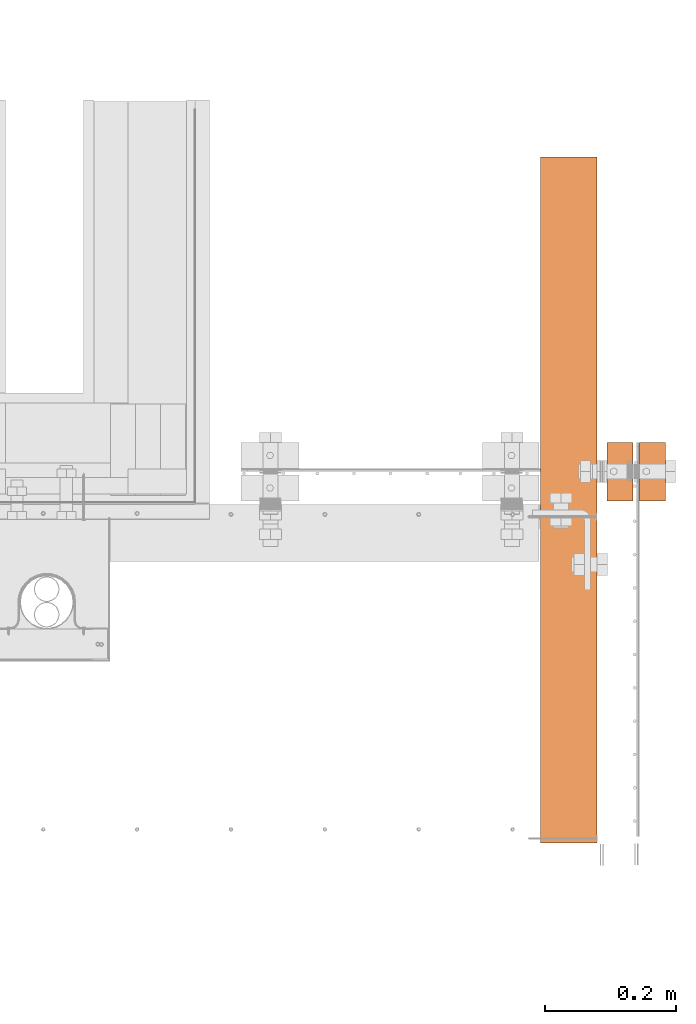
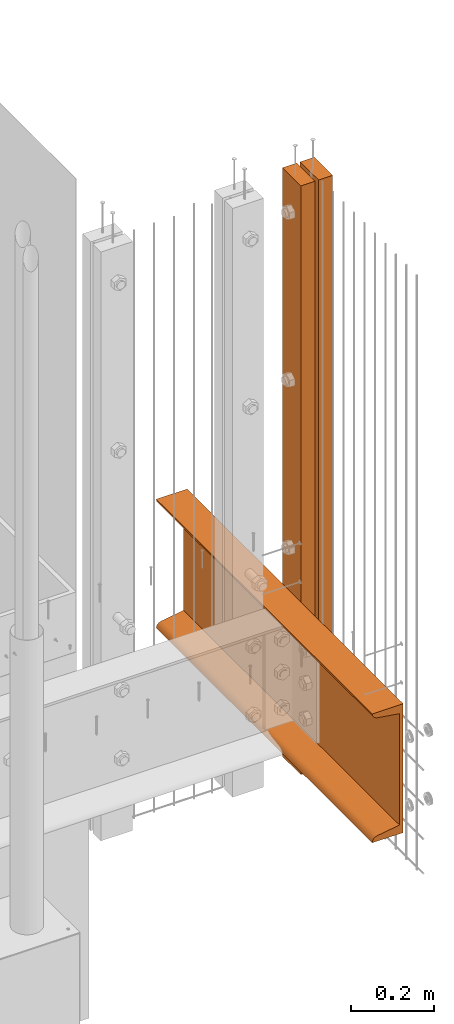
# One storey, part 10 of 44: 2 proxies.
"""IFC4 building model written with IfcOpenShell, lengths in feet."""

from ifc_helpers import new_model, entity, si_unit, converted_unit, derived_unit, direction, frame, frame_2d, origin, place, context, subcontext, project, spatial, polyline, circle_curve, parameter, trimmed, segment, composite_curve, rectangle, outline, extrude, source, transform, mapped, material, type_object, type_shapes, element, save


model = new_model("IFC4")

# Units and contexts
model_context = context("Model", 3, precision=0.0001, world=origin(), true_north=direction((6.12303176911189e-17, 1.0)))
body_context = subcontext(model_context, "Body", "Model", "MODEL_VIEW")
ifc_project = project(units=[converted_unit("LENGTHUNIT", "FOOT", entity("IfcRatioMeasure", 0.3048), si_unit("LENGTHUNIT", "METRE"), dimensions=[1, 0, 0, 0, 0, 0, 0]), converted_unit("AREAUNIT", "SQUARE FOOT", entity("IfcRatioMeasure", 0.09290304), si_unit("AREAUNIT", "SQUARE_METRE"), dimensions=[2, 0, 0, 0, 0, 0, 0]), converted_unit("VOLUMEUNIT", "CUBIC FOOT", entity("IfcRatioMeasure", 0.028316846592), si_unit("VOLUMEUNIT", "CUBIC_METRE"), dimensions=[3, 0, 0, 0, 0, 0, 0]), converted_unit("PLANEANGLEUNIT", "DEGREE", entity("IfcRatioMeasure", 0.0174532925199433), si_unit("PLANEANGLEUNIT", "RADIAN"), dimensions=[0, 0, 0, 0, 0, 0, 0]), si_unit("MASSUNIT", "GRAM", prefix="KILO"), derived_unit("MASSDENSITYUNIT", [(si_unit("MASSUNIT", "GRAM", prefix="KILO"), 1), (si_unit("LENGTHUNIT", "METRE"), -3)]), derived_unit("MOMENTOFINERTIAUNIT", [(si_unit("LENGTHUNIT", "METRE"), 4)]), si_unit("TIMEUNIT", "SECOND"), si_unit("FREQUENCYUNIT", "HERTZ"), si_unit("THERMODYNAMICTEMPERATUREUNIT", "DEGREE_CELSIUS"), derived_unit("THERMALTRANSMITTANCEUNIT", [(si_unit("MASSUNIT", "GRAM", prefix="KILO"), 1), (si_unit("THERMODYNAMICTEMPERATUREUNIT", "KELVIN"), -1), (si_unit("TIMEUNIT", "SECOND"), -3)]), derived_unit("VOLUMETRICFLOWRATEUNIT", [(si_unit("LENGTHUNIT", "METRE"), 3), (si_unit("TIMEUNIT", "SECOND"), -1)]), si_unit("ELECTRICCURRENTUNIT", "AMPERE"), si_unit("ELECTRICVOLTAGEUNIT", "VOLT"), si_unit("POWERUNIT", "WATT"), si_unit("FORCEUNIT", "NEWTON"), si_unit("ILLUMINANCEUNIT", "LUX"), si_unit("LUMINOUSFLUXUNIT", "LUMEN"), si_unit("LUMINOUSINTENSITYUNIT", "CANDELA"), derived_unit("USERDEFINED", [(si_unit("MASSUNIT", "GRAM", prefix="KILO"), -1), (si_unit("LENGTHUNIT", "METRE"), -2), (si_unit("TIMEUNIT", "SECOND"), 3), (si_unit("LUMINOUSFLUXUNIT", "LUMEN"), 1)]), derived_unit("LINEARVELOCITYUNIT", [(si_unit("LENGTHUNIT", "METRE"), 1), (si_unit("TIMEUNIT", "SECOND"), -1)]), si_unit("PRESSUREUNIT", "PASCAL"), derived_unit("USERDEFINED", [(si_unit("LENGTHUNIT", "METRE"), -2), (si_unit("MASSUNIT", "GRAM", prefix="KILO"), 1), (si_unit("TIMEUNIT", "SECOND"), -2)]), derived_unit("LINEARFORCEUNIT", [(si_unit("MASSUNIT", "GRAM", prefix="KILO"), 1), (si_unit("LENGTHUNIT", "METRE"), 1), (si_unit("TIMEUNIT", "SECOND"), -2), (si_unit("LENGTHUNIT", "METRE"), -1)]), derived_unit("PLANARFORCEUNIT", [(si_unit("MASSUNIT", "GRAM", prefix="KILO"), 1), (si_unit("LENGTHUNIT", "METRE"), 1), (si_unit("TIMEUNIT", "SECOND"), -2), (si_unit("LENGTHUNIT", "METRE"), -2)])], contexts=[model_context])

# Site, building, storey
site_placement = place(None, origin())
site = spatial("IfcSite", under=ifc_project, at=site_placement, CompositionType="ELEMENT")
building_placement = place(site_placement, origin())
building = spatial("IfcBuilding", under=site, at=building_placement, CompositionType="ELEMENT")
storey_placement = place(building_placement, origin())
storey = spatial("IfcBuildingStorey", under=building, at=storey_placement, CompositionType="ELEMENT", Elevation=0.0)

# Proxies
ifc_material_1 = material(Name="STEEL C CHANNEL - HDG - SEE STRUCT", Category="Materials")
building_element_proxy_type_1 = type_object("IfcBuildingElementProxyType", Name="C CHANNEL 2:C CHANNEL 2", PredefinedType="NOTDEFINED", material=ifc_material_1)
shared_shape_1 = source(origin(), body_context, "Body", "SweptSolid", [
    extrude(outline(composite_curve([segment(polyline([(-0.138533545738937, -0.624999999999991), (0.144799787594366, -0.624999999999991)]), True, "CONTINUOUS"), segment(trimmed(circle_curve(frame_2d((0.0906331209278051, -0.62500000000002), x_axis=(0.0, 1.0)), 0.0541666666666707), [parameter(270.00000000003)], [parameter(351.184889492654)], True, "PARAMETER"), True, "CONTINUOUS"), segment(polyline([(0.0989339705497514, -0.571473149977555), (-0.105200212405634, -0.53981638043649)]), True, "CONTINUOUS"), segment(polyline([(-0.105200212405634, -0.539816380436488), (-0.105200212405634, 0.539816380436505)]), True, "CONTINUOUS"), segment(polyline([(-0.105200212405634, 0.539816380436505), (0.0989339705497514, 0.571473149977505)]), True, "CONTINUOUS"), segment(trimmed(circle_curve(frame_2d((0.0906331209278051, 0.625000000000014), x_axis=(0.0, -1.0)), 0.0541666666666707), [parameter(8.81511050734989)], [parameter(89.9999999999945)], True, "PARAMETER"), True, "CONTINUOUS"), segment(polyline([(0.144799787594366, 0.625000000000009), (-0.138533545738937, 0.625000000000009)]), True, "CONTINUOUS"), segment(polyline([(-0.138533545738937, 0.625000000000009), (-0.138533545738937, -0.624999999999991)]), True, "CONTINUOUS")], self_intersect=False)), frame((0.150033620389422, 0.0, 0.630233832794991), z_axis=(0.0, 1.0, 0.0), x_axis=(-1.0, 0.0, 0.0)), (0.0, 0.0, 1.0), 3.43184637379962),
])
type_shapes(building_element_proxy_type_1, [shared_shape_1])
proxy_1_placement = place(storey_placement, frame((1494.00372221306, 3.04611392999273, 8.66668665781359)))
element("IfcBuildingElementProxy", 1, at=proxy_1_placement, inside=storey, type_object=building_element_proxy_type_1, material=ifc_material_1, Name="C CHANNEL 2:C CHANNEL 2", ObjectType="C CHANNEL 2:C CHANNEL 2", PredefinedType="NOTDEFINED", context=body_context, shape_type="MappedRepresentation", body=[
    mapped(shared_shape_1, transform((0.0, 0.0, 0.0), scale=1.0)),
])
ifc_material_2 = material(Name="(2) 2X4s - EXT STAIN - DARK", Category="Materials")
building_element_proxy_type_2 = type_object("IfcBuildingElementProxyType", Name="RAILING 2:RAILING 2", PredefinedType="NOTDEFINED", material=ifc_material_2)
shared_shape_2 = source(origin(), body_context, "Body", "SweptSolid", [
    extrude(rectangle(XDim=0.291666666666666, YDim=0.129166666666833, at=frame_2d((-4.44089209850063e-16, -1.13686837721616e-13), x_axis=(1.0, 0.0))), frame((0.0645833333335304, 0.145833333333334, 0.0), z_axis=(0.0, 0.0, 1.0), x_axis=(0.0, -1.0, 0.0)), (0.0, 0.0, 1.0), 5.70833333333337),
    extrude(rectangle(XDim=0.129166666666606, YDim=0.291666666666667, at=frame_2d((0.0, 4.44089209850063e-16), x_axis=(1.0, 0.0))), frame((0.227083333333439, 0.145833333333336, 0.0), z_axis=(0.0, 0.0, 1.0), x_axis=(-1.0, 0.0, 0.0)), (0.0, 0.0, 1.0), 5.70833333333337),
])
type_shapes(building_element_proxy_type_2, [shared_shape_2])
proxy_2_placement = place(storey_placement, frame((1494.34228937919, 4.75787225520065, 8.1770833333333)))
element("IfcBuildingElementProxy", 2, at=proxy_2_placement, inside=storey, type_object=building_element_proxy_type_2, material=ifc_material_2, Name="RAILING 2:RAILING 2", ObjectType="RAILING 2:RAILING 2", PredefinedType="NOTDEFINED", context=body_context, shape_type="MappedRepresentation", body=[
    mapped(shared_shape_2, transform((0.0, 0.0, 0.0), scale=1.0)),
])

save(model, "model.ifc")
